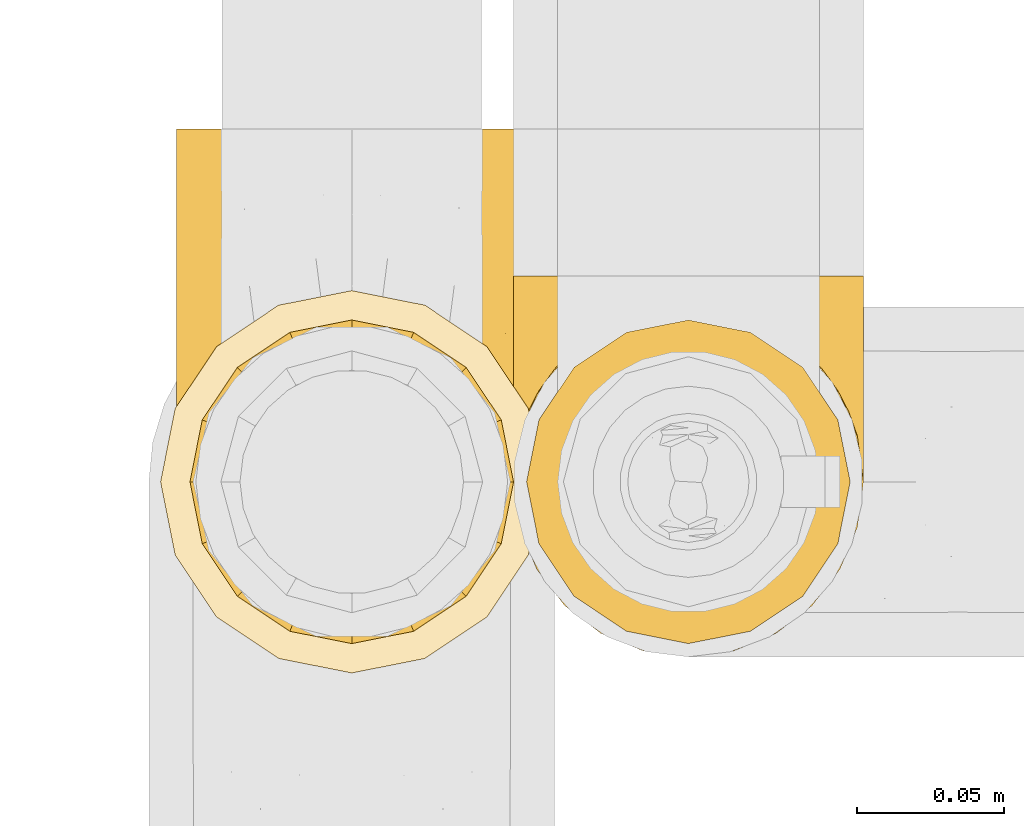
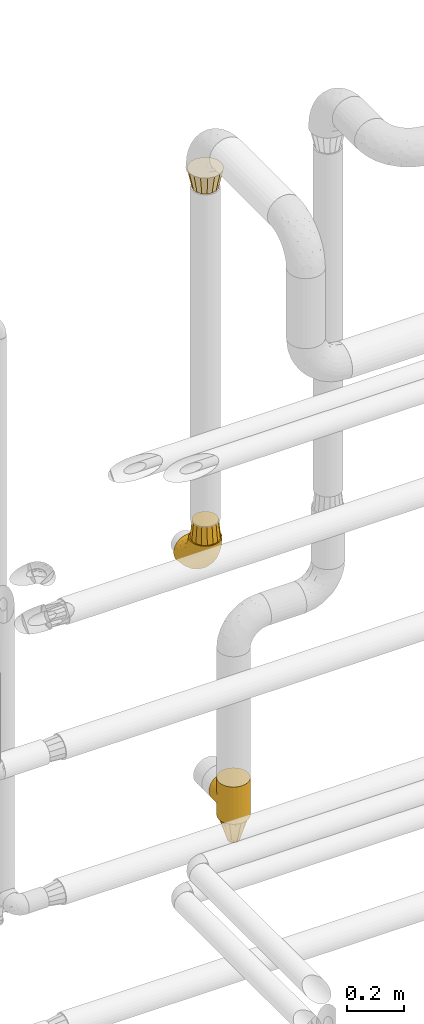
# One storey, part 483 of 827: 5 coverings.
"""IFC2X3 building model written with IfcOpenShell, lengths in millimetres."""

from ifc_helpers import new_model, entity, si_unit, converted_unit, derived_unit, direction, frame, origin, place, context, subcontext, project, spatial, faceted_brep, element, save


model = new_model("IFC2X3")

# Units and contexts
model_context = context("Model", 3, precision=0.01, world=origin(), true_north=direction((6.12303176911189e-17, 1.0)))
body_context = subcontext(model_context, "Body", "Model", "MODEL_VIEW")
ifc_project = project(units=[si_unit("LENGTHUNIT", "METRE", prefix="MILLI"), si_unit("AREAUNIT", "SQUARE_METRE"), si_unit("VOLUMEUNIT", "CUBIC_METRE"), converted_unit("PLANEANGLEUNIT", "DEGREE", entity("IfcRatioMeasure", 0.0174532925199433), si_unit("PLANEANGLEUNIT", "RADIAN"), dimensions=[0, 0, 0, 0, 0, 0, 0]), si_unit("MASSUNIT", "GRAM", prefix="KILO"), derived_unit("MASSDENSITYUNIT", [(si_unit("MASSUNIT", "GRAM", prefix="KILO"), 1), (si_unit("LENGTHUNIT", "METRE"), -3)]), derived_unit("MOMENTOFINERTIAUNIT", [(si_unit("LENGTHUNIT", "METRE"), 4)]), si_unit("TIMEUNIT", "SECOND"), si_unit("FREQUENCYUNIT", "HERTZ"), si_unit("THERMODYNAMICTEMPERATUREUNIT", "DEGREE_CELSIUS"), derived_unit("THERMALTRANSMITTANCEUNIT", [(si_unit("MASSUNIT", "GRAM", prefix="KILO"), 1), (si_unit("THERMODYNAMICTEMPERATUREUNIT", "KELVIN"), -1), (si_unit("TIMEUNIT", "SECOND"), -3)]), derived_unit("VOLUMETRICFLOWRATEUNIT", [(si_unit("LENGTHUNIT", "METRE"), 3), (si_unit("TIMEUNIT", "SECOND"), -1)]), derived_unit("MASSFLOWRATEUNIT", [(si_unit("MASSUNIT", "GRAM", prefix="KILO"), 1), (si_unit("TIMEUNIT", "SECOND"), -1)]), derived_unit("ROTATIONALFREQUENCYUNIT", [(si_unit("TIMEUNIT", "SECOND"), -1)]), si_unit("ELECTRICCURRENTUNIT", "AMPERE"), si_unit("ELECTRICVOLTAGEUNIT", "VOLT"), si_unit("POWERUNIT", "WATT"), si_unit("FORCEUNIT", "NEWTON", prefix="KILO"), si_unit("ILLUMINANCEUNIT", "LUX"), si_unit("LUMINOUSFLUXUNIT", "LUMEN"), si_unit("LUMINOUSINTENSITYUNIT", "CANDELA"), derived_unit("USERDEFINED", [(si_unit("MASSUNIT", "GRAM", prefix="KILO"), -1), (si_unit("LENGTHUNIT", "METRE"), -2), (si_unit("TIMEUNIT", "SECOND"), 3), (si_unit("LUMINOUSFLUXUNIT", "LUMEN"), 1)]), derived_unit("LINEARVELOCITYUNIT", [(si_unit("LENGTHUNIT", "METRE"), 1), (si_unit("TIMEUNIT", "SECOND"), -1)]), si_unit("PRESSUREUNIT", "PASCAL"), derived_unit("USERDEFINED", [(si_unit("LENGTHUNIT", "METRE"), -2), (si_unit("MASSUNIT", "GRAM", prefix="KILO"), 1), (si_unit("TIMEUNIT", "SECOND"), -2)]), derived_unit("LINEARFORCEUNIT", [(si_unit("MASSUNIT", "GRAM", prefix="KILO"), 1), (si_unit("LENGTHUNIT", "METRE"), 1), (si_unit("TIMEUNIT", "SECOND"), -2), (si_unit("LENGTHUNIT", "METRE"), -1)]), derived_unit("PLANARFORCEUNIT", [(si_unit("MASSUNIT", "GRAM", prefix="KILO"), 1), (si_unit("LENGTHUNIT", "METRE"), 1), (si_unit("TIMEUNIT", "SECOND"), -2), (si_unit("LENGTHUNIT", "METRE"), -2)])], contexts=[model_context])

# Site, building, storey
site_placement = place(None, origin())
site = spatial("IfcSite", under=ifc_project, at=site_placement, CompositionType="ELEMENT")
building_placement = place(site_placement, origin())
building = spatial("IfcBuilding", under=site, at=building_placement, CompositionType="ELEMENT")
storey_placement = place(building_placement, frame((0.0, 0.0, 28200.0)))
storey = spatial("IfcBuildingStorey", under=building, at=storey_placement, Name="08", CompositionType="ELEMENT", Elevation=28200.0)

# Coverings
covering_1_placement = place(storey_placement, frame((55549.95, 18574.89, 1587.07)))
element("IfcCovering", 1, at=covering_1_placement, inside=storey, Name=":ADSK_", ObjectType=":ADSK_", PredefinedType="INSULATION", context=body_context, shape_type="Brep", body=[
    faceted_brep([(119.1, 181.1, 47.85), (114.7, 181.1, 35.28), (107.61, 181.1, 23.99), (98.19, 181.1, 14.57), (86.9, 181.1, 7.48), (74.32, 181.1, 3.08), (61.1, 181.1, 1.6), (47.85, 181.1, 3.09), (35.28, 181.1, 7.49), (23.99, 181.1, 14.58), (14.57, 181.1, 24.0), (7.48, 181.1, 35.29), (3.08, 181.1, 47.87), (1.6, 181.1, 61.1), (3.09, 181.1, 74.34), (7.49, 181.1, 86.92), (14.58, 181.1, 98.2), (24.0, 181.1, 107.62), (35.29, 181.1, 114.71), (47.87, 181.1, 119.11), (61.1, 181.1, 120.6), (74.34, 181.1, 119.1), (86.92, 181.1, 114.7), (98.2, 181.1, 107.61), (107.62, 181.1, 98.19), (114.71, 181.1, 86.9), (119.11, 181.1, 74.32), (120.6, 181.1, 61.1), (45.7, 118.57, 181.1), (31.35, 112.62, 181.1), (19.02, 103.17, 181.1), (9.57, 90.85, 181.1), (3.62, 76.5, 181.1), (1.6, 61.1, 181.1), (3.62, 45.7, 181.1), (9.57, 31.35, 181.1), (19.02, 19.02, 181.1), (31.35, 9.57, 181.1), (45.7, 3.62, 181.1), (61.1, 1.6, 181.1), (76.5, 3.62, 181.1), (90.85, 9.57, 181.1), (103.17, 19.02, 181.1), (112.62, 31.35, 181.1), (118.57, 45.7, 181.1), (120.6, 61.1, 181.1), (118.57, 76.5, 181.1), (112.62, 90.85, 181.1), (103.17, 103.17, 181.1), (90.85, 112.62, 181.1), (76.5, 118.57, 181.1), (61.1, 120.6, 181.1), (95.88, 15.84, 149.36), (82.3, 10.89, 137.95), (94.1, 25.99, 112.73), (71.89, 6.8, 142.53), (61.1, 7.71, 134.64), (110.03, 148.3, 30.78), (80.11, 40.83, 74.16), (61.1, 25.64, 91.35), (61.1, 54.17, 54.17), (115.76, 56.92, 109.16), (113.03, 40.2, 132.51), (106.83, 45.07, 100.6), (118.0, 48.97, 143.49), (119.56, 66.12, 118.25), (91.22, 66.35, 53.89), (97.67, 45.15, 84.22), (83.16, 22.59, 106.32), (71.84, 15.89, 113.45), (106.27, 28.43, 137.68), (61.1, 134.64, 7.71), (79.29, 137.7, 9.86), (89.43, 106.92, 25.56), (76.37, 73.35, 40.03), (73.84, 104.34, 20.36), (118.7, 85.71, 85.71), (113.14, 75.83, 75.88), (114.84, 115.33, 51.26), (119.09, 132.84, 56.83), (120.6, 110.56, 84.01), (120.6, 84.01, 110.56), (120.6, 75.49, 127.29), (120.6, 66.97, 144.01), (61.1, 91.35, 25.64), (101.09, 137.45, 22.95), (106.71, 109.24, 40.15), (91.36, 148.74, 12.95), (116.15, 149.72, 42.03), (120.6, 166.46, 63.41), (120.6, 144.01, 66.97), (98.77, 108.21, 31.89), (120.6, 97.29, 97.29), (104.27, 67.3, 67.3), (120.6, 127.29, 75.49), (120.6, 63.41, 166.46), (114.26, 96.71, 141.36), (113.3, 111.53, 121.72), (106.08, 112.34, 138.16), (118.29, 79.69, 159.88), (119.17, 88.09, 128.08), (102.39, 126.83, 126.23), (119.07, 100.88, 110.87), (74.66, 121.74, 162.96), (72.06, 130.15, 146.61), (61.1, 125.2, 157.94), (107.18, 157.86, 102.08), (103.18, 144.96, 112.03), (111.64, 131.95, 107.36), (111.23, 95.04, 162.91), (101.44, 108.45, 157.88), (82.78, 166.95, 118.07), (95.99, 162.57, 111.72), (88.46, 120.76, 151.58), (85.34, 116.83, 167.61), (75.22, 141.74, 132.93), (61.1, 138.32, 138.32), (116.35, 144.64, 90.2), (119.46, 127.06, 87.09), (116.78, 126.54, 98.46), (85.13, 150.94, 122.87), (89.52, 133.58, 132.83), (119.0, 161.98, 76.52), (94.63, 149.89, 117.49), (113.92, 164.37, 90.0), (73.67, 158.61, 123.48), (61.1, 157.94, 125.2), (119.4, 112.57, 97.44), (97.35, 121.02, 139.94), (119.56, 141.14, 79.72), (117.72, 85.77, 145.56), (108.82, 101.62, 152.47), (16.12, 112.36, 138.17), (19.81, 126.84, 126.24), (8.9, 111.54, 121.74), (26.21, 162.57, 111.73), (15.02, 157.85, 102.09), (24.86, 121.04, 139.94), (5.84, 144.61, 90.22), (2.63, 141.17, 79.72), (2.73, 127.06, 87.08), (46.99, 141.76, 132.91), (47.54, 121.74, 162.97), (36.85, 116.83, 167.61), (10.96, 95.04, 162.91), (13.37, 101.62, 152.47), (7.93, 96.71, 141.36), (3.02, 88.09, 128.08), (2.89, 98.49, 112.07), (1.6, 84.01, 110.56), (3.9, 79.69, 159.88), (1.6, 63.41, 166.46), (26.96, 141.74, 121.68), (37.08, 150.97, 122.86), (20.75, 108.45, 157.88), (10.56, 131.95, 107.38), (50.11, 130.15, 146.61), (19.02, 144.96, 112.05), (48.54, 158.63, 123.48), (3.81, 114.02, 101.72), (8.27, 164.36, 90.01), (4.47, 85.77, 145.56), (39.43, 166.97, 118.07), (3.19, 161.97, 76.53), (32.68, 133.61, 132.81), (1.6, 144.01, 66.97), (1.6, 166.46, 63.41), (1.6, 127.29, 75.49), (5.87, 130.93, 97.07), (1.6, 97.29, 97.29), (1.6, 66.97, 144.01), (1.6, 75.49, 127.29), (1.6, 110.56, 84.01), (33.73, 120.76, 151.59), (28.09, 25.99, 112.73), (26.31, 15.84, 149.36), (15.92, 28.43, 137.68), (9.16, 40.2, 132.51), (50.3, 6.8, 142.53), (39.89, 10.89, 137.95), (50.35, 15.89, 113.45), (2.63, 66.12, 118.25), (15.36, 45.07, 100.6), (45.82, 73.35, 40.03), (30.97, 66.35, 53.89), (32.75, 106.93, 25.56), (3.49, 85.71, 85.71), (4.19, 48.97, 143.49), (39.03, 22.59, 106.32), (44.85, 103.99, 21.51), (42.89, 137.71, 9.86), (42.08, 40.83, 74.16), (6.03, 149.72, 42.04), (3.1, 132.83, 56.84), (6.43, 56.92, 109.16), (9.05, 75.83, 75.88), (12.15, 148.31, 30.8), (21.09, 137.46, 22.96), (24.52, 45.15, 84.22), (30.82, 148.74, 12.96), (7.35, 115.32, 51.28), (15.47, 109.25, 40.16), (17.92, 67.3, 67.3), (23.41, 108.22, 31.9)], [[[0, 1, 2, 3, 4, 5, 6, 7, 8, 9, 10, 11, 12, 13, 14, 15, 16, 17, 18, 19, 20, 21, 22, 23, 24, 25, 26, 27]], [[28, 29, 30, 31, 32, 33, 34, 35, 36, 37, 38, 39, 40, 41, 42, 43, 44, 45, 46, 47, 48, 49, 50, 51]], [[52, 53, 54]], [[55, 39, 56]], [[57, 2, 1]], [[58, 59, 60]], [[61, 62, 63]], [[64, 61, 65]], [[58, 66, 67]], [[53, 68, 54]], [[41, 40, 53]], [[53, 69, 68]], [[70, 42, 52]], [[42, 41, 52]], [[71, 5, 72]], [[73, 74, 75]], [[43, 70, 62]], [[45, 44, 64]], [[76, 77, 78]], [[79, 80, 76]], [[65, 81, 82, 83]], [[74, 60, 84]], [[85, 2, 57]], [[85, 57, 86]], [[2, 85, 3]], [[42, 70, 43]], [[5, 4, 72]], [[72, 87, 73]], [[4, 3, 87]], [[5, 71, 6]], [[75, 74, 84]], [[64, 62, 61]], [[79, 78, 88]], [[54, 67, 63]], [[74, 58, 60]], [[65, 76, 81]], [[79, 27, 89, 90]], [[75, 71, 72]], [[85, 86, 91]], [[78, 57, 88]], [[56, 69, 55]], [[76, 78, 79]], [[76, 80, 92, 81]], [[77, 76, 61]], [[69, 56, 59]], [[4, 87, 72]], [[91, 66, 73]], [[58, 74, 66]], [[3, 85, 87]], [[73, 87, 85]], [[88, 57, 1]], [[86, 57, 78]], [[77, 86, 78]], [[93, 66, 91]], [[73, 66, 74]], [[67, 93, 63]], [[1, 0, 88]], [[0, 27, 79]], [[0, 79, 88]], [[79, 90, 94, 80]], [[64, 83, 95, 45]], [[76, 65, 61]], [[83, 64, 65]], [[62, 44, 43]], [[62, 64, 44]], [[63, 62, 70]], [[54, 63, 70]], [[63, 93, 77]], [[63, 77, 61]], [[77, 93, 86]], [[67, 54, 68]], [[66, 93, 67]], [[53, 52, 41]], [[70, 52, 54]], [[58, 69, 59]], [[55, 69, 53]], [[69, 58, 68]], [[67, 68, 58]], [[53, 40, 55]], [[39, 55, 40]], [[71, 75, 84]], [[73, 75, 72]], [[91, 86, 93]], [[73, 85, 91]], [[96, 97, 98]], [[83, 99, 95]], [[82, 81, 100]], [[95, 99, 46]], [[101, 98, 97]], [[47, 46, 99]], [[97, 100, 102]], [[103, 104, 105]], [[106, 107, 108]], [[109, 48, 47]], [[48, 110, 49]], [[108, 101, 97]], [[111, 112, 22]], [[51, 50, 103]], [[113, 103, 114]], [[23, 22, 112]], [[115, 116, 104]], [[108, 117, 106]], [[112, 106, 23]], [[94, 118, 80]], [[108, 119, 117]], [[120, 115, 121]], [[112, 107, 106]], [[25, 122, 26]], [[122, 89, 26]], [[101, 123, 121]], [[109, 110, 48]], [[124, 25, 24]], [[125, 20, 126]], [[120, 111, 125]], [[110, 113, 114]], [[127, 97, 102]], [[106, 24, 23]], [[125, 115, 120]], [[111, 22, 21]], [[126, 115, 125]], [[117, 124, 106]], [[110, 98, 128]], [[117, 129, 124]], [[117, 118, 129]], [[100, 97, 96]], [[124, 122, 25]], [[83, 82, 130]], [[99, 130, 109]], [[100, 81, 102]], [[100, 130, 82]], [[130, 100, 96]], [[81, 92, 102]], [[127, 80, 118]], [[21, 20, 125]], [[111, 120, 123]], [[21, 125, 111]], [[115, 126, 116]], [[104, 116, 105]], [[101, 107, 123]], [[104, 121, 115]], [[128, 121, 113]], [[105, 51, 103]], [[121, 104, 113]], [[114, 103, 50]], [[113, 104, 103]], [[106, 124, 24]], [[94, 129, 118]], [[123, 107, 112]], [[101, 108, 107]], [[99, 109, 47]], [[131, 109, 96]], [[89, 122, 90]], [[89, 27, 26]], [[122, 129, 90]], [[97, 127, 119]], [[119, 127, 118]], [[102, 92, 127]], [[90, 129, 94]], [[80, 127, 92]], [[124, 129, 122]], [[117, 119, 118]], [[97, 119, 108]], [[50, 49, 114]], [[110, 114, 49]], [[109, 130, 96]], [[130, 99, 83]], [[128, 98, 101]], [[98, 110, 131]], [[121, 128, 101]], [[110, 128, 113]], [[46, 45, 95]], [[111, 123, 112]], [[121, 123, 120]], [[98, 131, 96]], [[110, 109, 131]], [[132, 133, 134]], [[135, 17, 136]], [[132, 137, 133]], [[138, 139, 140]], [[126, 141, 116]], [[105, 142, 51]], [[16, 136, 17]], [[142, 143, 28]], [[144, 145, 146]], [[147, 148, 149]], [[31, 150, 32]], [[150, 151, 32]], [[135, 152, 153]], [[30, 29, 154]], [[155, 136, 138]], [[31, 30, 144]], [[156, 116, 141]], [[136, 155, 157]], [[126, 158, 141]], [[159, 148, 134]], [[20, 19, 158]], [[156, 142, 105]], [[160, 136, 16]], [[147, 161, 146]], [[135, 18, 17]], [[18, 162, 19]], [[136, 157, 135]], [[146, 145, 132]], [[160, 163, 139]], [[16, 15, 160]], [[15, 14, 163]], [[164, 141, 153]], [[133, 155, 134]], [[152, 135, 157]], [[165, 163, 166]], [[163, 14, 166]], [[162, 135, 153]], [[29, 143, 154]], [[165, 167, 139]], [[162, 158, 19]], [[159, 134, 155]], [[167, 140, 139]], [[140, 168, 138]], [[159, 169, 148]], [[144, 150, 31]], [[161, 170, 150]], [[171, 170, 161]], [[149, 171, 147]], [[134, 147, 146]], [[134, 148, 147]], [[135, 162, 18]], [[169, 159, 172]], [[169, 149, 148]], [[158, 162, 153]], [[158, 153, 141]], [[158, 126, 20]], [[153, 152, 164]], [[116, 156, 105]], [[137, 164, 133]], [[156, 164, 173]], [[164, 156, 141]], [[142, 28, 51]], [[156, 173, 142]], [[143, 142, 173]], [[163, 160, 15]], [[136, 160, 138]], [[155, 133, 157]], [[133, 164, 152]], [[154, 144, 30]], [[144, 146, 161]], [[14, 13, 166]], [[172, 159, 140]], [[140, 167, 172]], [[168, 159, 155]], [[160, 139, 138]], [[165, 139, 163]], [[154, 143, 173]], [[29, 28, 143]], [[171, 161, 147]], [[144, 161, 150]], [[159, 168, 140]], [[155, 138, 168]], [[146, 132, 134]], [[137, 154, 173]], [[154, 137, 132]], [[164, 137, 173]], [[151, 150, 170]], [[151, 33, 32]], [[133, 152, 157]], [[144, 154, 145]], [[132, 145, 154]], [[174, 175, 176]], [[35, 34, 177]], [[178, 179, 180]], [[181, 170, 171, 149]], [[176, 182, 174]], [[183, 184, 185]], [[186, 149, 169, 172]], [[187, 33, 151, 170]], [[179, 188, 180]], [[34, 187, 177]], [[39, 38, 178]], [[189, 185, 190]], [[184, 183, 191]], [[175, 179, 37]], [[38, 37, 179]], [[35, 176, 36]], [[180, 59, 56]], [[192, 193, 12]], [[37, 36, 175]], [[181, 187, 170]], [[181, 186, 194]], [[176, 177, 182]], [[8, 7, 190]], [[194, 186, 195]], [[13, 12, 193]], [[196, 192, 11]], [[10, 9, 197]], [[60, 183, 84]], [[174, 182, 198]], [[197, 196, 10]], [[193, 172, 167, 165]], [[8, 199, 9]], [[189, 183, 185]], [[60, 59, 191]], [[200, 196, 201]], [[190, 199, 8]], [[7, 6, 71]], [[10, 196, 11]], [[202, 203, 184]], [[199, 185, 197]], [[7, 71, 190]], [[183, 60, 191]], [[189, 71, 84]], [[193, 186, 172]], [[200, 201, 195]], [[180, 191, 59]], [[185, 199, 190]], [[197, 9, 199]], [[201, 196, 197]], [[192, 196, 200]], [[203, 201, 197]], [[195, 201, 202]], [[191, 188, 198]], [[202, 201, 203]], [[193, 192, 200]], [[12, 11, 192]], [[186, 193, 200]], [[193, 165, 166, 13]], [[186, 181, 149]], [[187, 181, 194]], [[187, 194, 177]], [[187, 34, 33]], [[194, 195, 182]], [[35, 177, 176]], [[194, 182, 177]], [[182, 202, 198]], [[200, 195, 186]], [[182, 195, 202]], [[202, 184, 198]], [[191, 198, 184]], [[176, 175, 36]], [[179, 175, 174]], [[178, 180, 56]], [[179, 174, 188]], [[198, 188, 174]], [[191, 180, 188]], [[39, 178, 56]], [[38, 179, 178]], [[71, 189, 190]], [[84, 183, 189]], [[197, 185, 203]], [[184, 203, 185]]]),
])
covering_2_placement = place(storey_placement, frame((55664.4, 18574.89, 535.5)))
element("IfcCovering", 2, at=covering_2_placement, inside=storey, Name=":ADSK_", ObjectType=":ADSK_", PredefinedType="INSULATION", context=body_context, shape_type="Brep", body=[
    faceted_brep([(120.05, 69.11, 71.99), (120.6, 61.1, 0.0), (118.57, 76.5, 0.0), (112.62, 90.85, 0.0), (115.66, 84.83, 56.27), (106.54, 99.5, 41.59), (103.17, 103.17, 0.0), (111.72, 92.36, 48.74), (120.6, 61.1, 80.0), (120.05, 69.11, 88.01), (120.6, 61.1, 160.0), (118.42, 77.05, 64.05), (100.03, 106.08, 35.01), (90.85, 112.62, 0.0), (82.85, 116.47, 24.62), (83.67, 115.6, 0.0), (76.5, 118.57, 0.0), (68.8, 119.58, 0.0), (61.1, 120.6, 0.0), (61.1, 120.6, 20.5), (68.8, 119.58, 160.0), (61.1, 120.6, 139.5), (61.1, 120.6, 160.0), (92.14, 111.85, 29.24), (72.35, 119.52, 21.57), (77.6, 118.0, 23.1), (66.72, 120.06, 21.04), (49.85, 119.52, 21.57), (53.4, 119.58, 0.0), (45.7, 118.57, 0.0), (39.34, 116.48, 24.62), (38.52, 115.6, 0.0), (31.35, 112.62, 0.0), (22.16, 106.09, 35.01), (19.02, 103.17, 0.0), (55.47, 120.06, 21.04), (53.4, 119.58, 160.0), (30.06, 111.86, 29.24), (44.6, 118.0, 23.1), (15.66, 99.51, 41.59), (10.47, 92.37, 48.73), (9.57, 90.85, 0.0), (6.54, 84.83, 56.26), (3.62, 76.5, 0.0), (2.14, 69.11, 71.99), (1.6, 61.1, 0.0), (3.77, 77.05, 64.05), (1.6, 61.1, 80.0), (2.14, 69.11, 88.01), (1.6, 61.1, 160.0), (31.35, 9.57, 160.0), (45.7, 3.62, 160.0), (61.1, 1.6, 160.0), (76.5, 3.62, 160.0), (90.85, 9.57, 160.0), (103.17, 19.02, 160.0), (112.62, 31.35, 160.0), (118.57, 45.7, 160.0), (118.57, 76.5, 160.0), (112.62, 90.85, 160.0), (103.17, 103.17, 160.0), (90.85, 112.62, 160.0), (83.67, 115.6, 160.0), (76.5, 118.57, 160.0), (45.7, 118.57, 160.0), (38.52, 115.6, 160.0), (31.35, 112.62, 160.0), (19.02, 103.17, 160.0), (9.57, 90.85, 160.0), (3.62, 76.5, 160.0), (3.62, 45.7, 160.0), (9.57, 31.35, 160.0), (19.02, 19.02, 160.0), (118.57, 45.7, 0.0), (112.62, 31.35, 0.0), (103.17, 19.02, 0.0), (90.85, 9.57, 0.0), (76.5, 3.62, 0.0), (61.1, 1.6, 0.0), (45.7, 3.62, 0.0), (31.35, 9.57, 0.0), (19.02, 19.02, 0.0), (9.57, 31.35, 0.0), (3.62, 45.7, 0.0), (118.42, 77.05, 95.95), (115.66, 84.83, 103.73), (111.72, 92.36, 111.26), (106.54, 99.5, 118.41), (100.03, 106.08, 124.99), (92.14, 111.85, 130.76), (82.85, 116.47, 135.38), (77.6, 118.0, 136.9), (72.35, 119.52, 138.43), (66.72, 120.06, 138.96), (49.85, 119.52, 138.43), (44.6, 118.0, 136.9), (39.34, 116.48, 135.38), (30.06, 111.86, 130.76), (22.16, 106.09, 124.99), (55.47, 120.06, 138.96), (15.66, 99.51, 118.41), (6.54, 84.83, 103.74), (3.77, 77.05, 95.95), (10.47, 92.37, 111.27), (118.57, 131.1, 64.6), (112.62, 131.1, 50.25), (103.17, 131.1, 37.93), (90.85, 131.1, 28.47), (83.67, 131.1, 25.5), (76.5, 131.1, 22.53), (72.65, 131.1, 22.02), (68.8, 131.1, 21.51), (64.95, 131.1, 21.01), (61.1, 131.1, 20.5), (57.25, 131.1, 21.01), (53.4, 131.1, 21.51), (49.55, 131.1, 22.02), (45.7, 131.1, 22.53), (38.52, 131.1, 25.5), (31.35, 131.1, 28.47), (19.02, 131.1, 37.93), (9.57, 131.1, 50.25), (3.62, 131.1, 64.6), (1.6, 131.1, 80.0), (3.62, 131.1, 95.4), (9.57, 131.1, 109.75), (19.02, 131.1, 122.07), (31.35, 131.1, 131.53), (38.52, 131.1, 134.5), (45.7, 131.1, 137.47), (49.55, 131.1, 137.98), (53.4, 131.1, 138.49), (57.25, 131.1, 138.99), (61.1, 131.1, 139.5), (64.95, 131.1, 138.99), (68.8, 131.1, 138.49), (72.65, 131.1, 137.98), (76.5, 131.1, 137.47), (83.67, 131.1, 134.5), (90.85, 131.1, 131.53), (103.17, 131.1, 122.07), (112.62, 131.1, 109.75), (118.57, 131.1, 95.4), (120.6, 131.1, 80.0)], [[[0, 1, 2]], [[2, 3, 4]], [[5, 3, 6]], [[5, 7, 3]], [[0, 8, 1]], [[8, 9, 10]], [[4, 11, 2]], [[7, 4, 3]], [[0, 2, 11]], [[12, 6, 13]], [[14, 13, 15, 16]], [[17, 18, 19]], [[20, 21, 22]], [[23, 12, 13]], [[16, 24, 25, 14]], [[17, 19, 26, 24]], [[24, 16, 17]], [[23, 13, 14]], [[6, 12, 5]], [[27, 28, 29]], [[30, 29, 31, 32]], [[33, 32, 34]], [[28, 27, 35, 19]], [[19, 18, 28]], [[22, 21, 36]], [[37, 30, 32]], [[33, 37, 32]], [[29, 30, 38, 27]], [[34, 39, 33]], [[40, 39, 41]], [[41, 39, 34]], [[42, 41, 43]], [[44, 43, 45]], [[42, 40, 41]], [[44, 46, 43]], [[47, 44, 45]], [[48, 47, 49]], [[42, 43, 46]], [[50, 51, 52, 53, 54, 55, 56, 57, 10, 58, 59, 60, 61, 62, 63, 20, 22, 36, 64, 65, 66, 67, 68, 69, 49, 70, 71, 72]], [[73, 74, 75, 76, 77, 78, 79, 80, 81, 82, 83, 45, 43, 41, 34, 32, 31, 29, 28, 18, 17, 16, 15, 13, 6, 3, 2, 1]], [[76, 75, 55, 54]], [[52, 78, 77, 53]], [[53, 77, 76, 54]], [[56, 74, 73, 57]], [[1, 8, 10, 57, 73]], [[55, 75, 74, 56]], [[84, 85, 58]], [[9, 84, 58]], [[10, 9, 58]], [[59, 86, 87]], [[59, 58, 85]], [[59, 87, 60]], [[86, 59, 85]], [[88, 89, 61]], [[90, 63, 62, 61]], [[63, 90, 91, 92]], [[20, 92, 93, 21]], [[89, 90, 61]], [[60, 88, 61]], [[92, 20, 63]], [[88, 60, 87]], [[64, 94, 95, 96]], [[94, 64, 36]], [[97, 98, 66]], [[96, 66, 65, 64]], [[96, 97, 66]], [[36, 21, 99, 94]], [[98, 67, 66]], [[98, 100, 67]], [[101, 102, 69]], [[102, 48, 69]], [[100, 103, 68]], [[101, 68, 103]], [[101, 69, 68]], [[48, 49, 69]], [[100, 68, 67]], [[47, 45, 83, 70, 49]], [[70, 83, 82, 71]], [[82, 81, 72, 71]], [[72, 81, 80, 50]], [[50, 80, 79, 51]], [[51, 79, 78, 52]], [[104, 105, 106, 107, 108, 109, 110, 111, 112, 113, 114, 115, 116, 117, 118, 119, 120, 121, 122, 123, 124, 125, 126, 127, 128, 129, 130, 131, 132, 133, 134, 135, 136, 137, 138, 139, 140, 141, 142, 143]], [[24, 111, 110, 109]], [[107, 106, 12]], [[19, 112, 26]], [[14, 108, 107]], [[112, 19, 113]], [[112, 111, 26]], [[108, 25, 109]], [[23, 14, 107]], [[12, 23, 107]], [[25, 108, 14]], [[24, 109, 25]], [[106, 5, 12]], [[7, 5, 105]], [[105, 5, 106]], [[4, 105, 104]], [[0, 104, 143]], [[4, 7, 105]], [[0, 11, 104]], [[8, 0, 143]], [[4, 104, 11]], [[111, 24, 26]], [[9, 143, 142]], [[142, 141, 85]], [[87, 141, 140]], [[87, 86, 141]], [[9, 8, 143]], [[93, 135, 134]], [[85, 84, 142]], [[86, 85, 141]], [[9, 142, 84]], [[21, 134, 133]], [[88, 140, 139]], [[138, 137, 91]], [[21, 93, 134]], [[137, 92, 91]], [[89, 88, 139]], [[90, 139, 138]], [[90, 138, 91]], [[92, 135, 93]], [[92, 137, 136, 135]], [[89, 139, 90]], [[140, 88, 87]], [[94, 131, 130, 129]], [[96, 128, 127]], [[98, 127, 126]], [[132, 21, 133]], [[132, 131, 99]], [[128, 95, 129]], [[97, 96, 127]], [[98, 97, 127]], [[95, 128, 96]], [[94, 129, 95]], [[126, 100, 98]], [[103, 100, 125]], [[125, 100, 126]], [[101, 125, 124]], [[48, 124, 123]], [[101, 103, 125]], [[48, 102, 124]], [[47, 48, 123]], [[101, 124, 102]], [[21, 132, 99]], [[131, 94, 99]], [[44, 123, 122]], [[122, 121, 42]], [[39, 121, 120]], [[39, 40, 121]], [[44, 47, 123]], [[35, 115, 114]], [[42, 46, 122]], [[40, 42, 121]], [[44, 122, 46]], [[19, 114, 113]], [[33, 120, 119]], [[118, 117, 38]], [[19, 35, 114]], [[117, 27, 38]], [[37, 33, 119]], [[30, 119, 118]], [[30, 118, 38]], [[27, 115, 35]], [[27, 117, 116, 115]], [[37, 119, 30]], [[120, 33, 39]]]),
])
covering_3_placement = place(storey_placement, frame((55668.9, 18579.39, 430.5)))
element("IfcCovering", 3, at=covering_3_placement, inside=storey, Name=":ADSK_", ObjectType=":ADSK_", PredefinedType="INSULATION", context=body_context, shape_type="Brep", body=[
    faceted_brep([(101.45, 86.56, 105.0), (95.49, 95.49, 105.0), (86.56, 101.45, 105.0), (77.64, 107.41, 105.0), (67.12, 109.5, 105.0), (56.6, 111.6, 105.0), (46.07, 109.5, 105.0), (35.55, 107.41, 105.0), (26.63, 101.45, 105.0), (17.7, 95.49, 105.0), (11.74, 86.56, 105.0), (5.78, 77.64, 105.0), (3.69, 67.12, 105.0), (1.6, 56.6, 105.0), (3.69, 46.07, 105.0), (5.78, 35.55, 105.0), (11.74, 26.63, 105.0), (17.7, 17.7, 105.0), (26.63, 11.74, 105.0), (35.55, 5.78, 105.0), (46.07, 3.69, 105.0), (56.6, 1.6, 105.0), (67.12, 3.69, 105.0), (77.64, 5.78, 105.0), (86.56, 11.74, 105.0), (95.49, 17.7, 105.0), (101.45, 26.63, 105.0), (107.41, 35.55, 105.0), (109.5, 46.07, 105.0), (111.6, 56.6, 105.0), (109.5, 67.12, 105.0), (107.41, 77.64, 105.0), (76.08, 45.35, 0.0), (71.96, 41.23, 0.0), (67.85, 37.11, 0.0), (62.22, 35.6, 0.0), (56.6, 34.1, 0.0), (50.97, 35.6, 0.0), (45.35, 37.11, 0.0), (41.23, 41.23, 0.0), (37.11, 45.35, 0.0), (35.6, 50.97, 0.0), (34.1, 56.6, 0.0), (35.6, 62.22, 0.0), (37.11, 67.85, 0.0), (41.23, 71.96, 0.0), (45.35, 76.08, 0.0), (50.97, 77.59, 0.0), (56.6, 79.1, 0.0), (62.22, 77.59, 0.0), (67.85, 76.08, 0.0), (71.96, 71.96, 0.0), (76.08, 67.85, 0.0), (77.59, 62.22, 0.0), (79.1, 56.6, 0.0), (77.59, 50.97, 0.0)], [[[0, 1, 2, 3, 4, 5, 6, 7, 8, 9, 10, 11, 12, 13, 14, 15, 16, 17, 18, 19, 20, 21, 22, 23, 24, 25, 26, 27, 28, 29, 30, 31]], [[32, 33, 34, 35, 36, 37, 38, 39, 40, 41, 42, 43, 44, 45, 46, 47, 48, 49, 50, 51, 52, 53, 54, 55]], [[6, 5, 48]], [[44, 10, 45]], [[45, 8, 46]], [[48, 47, 6]], [[9, 45, 10]], [[8, 7, 46]], [[8, 45, 9]], [[42, 12, 43]], [[47, 7, 6]], [[47, 46, 7]], [[12, 42, 13]], [[11, 44, 43]], [[12, 11, 43]], [[44, 11, 10]], [[14, 13, 42]], [[38, 18, 39]], [[39, 16, 40]], [[42, 41, 14]], [[17, 39, 18]], [[16, 15, 40]], [[16, 39, 17]], [[36, 20, 37]], [[41, 15, 14]], [[41, 40, 15]], [[20, 36, 21]], [[19, 38, 37]], [[20, 19, 37]], [[38, 19, 18]], [[22, 21, 36]], [[32, 26, 33]], [[33, 24, 34]], [[36, 35, 22]], [[25, 33, 26]], [[24, 23, 34]], [[24, 33, 25]], [[54, 28, 55]], [[35, 23, 22]], [[35, 34, 23]], [[28, 54, 29]], [[27, 32, 55]], [[28, 27, 55]], [[32, 27, 26]], [[30, 29, 54]], [[50, 2, 51]], [[51, 0, 52]], [[54, 53, 30]], [[1, 51, 2]], [[0, 31, 52]], [[0, 51, 1]], [[48, 4, 49]], [[53, 31, 30]], [[53, 52, 31]], [[4, 48, 5]], [[3, 50, 49]], [[4, 3, 49]], [[50, 3, 2]]]),
])
covering_4_placement = place(storey_placement, frame((55544.45, 18569.39, 3269.74)))
element("IfcCovering", 4, at=covering_4_placement, inside=storey, Name=":ADSK_", ObjectType=":ADSK_", PredefinedType="INSULATION", context=body_context, shape_type="Brep", body=[
    faceted_brep([(57.51, 20.9, 0.0), (48.42, 22.71, 0.0), (40.71, 27.86, 0.0), (33.01, 33.01, 0.0), (27.86, 40.71, 0.0), (22.71, 48.42, 0.0), (20.9, 57.51, 0.0), (19.1, 66.6, 0.0), (20.9, 75.68, 0.0), (22.71, 84.77, 0.0), (27.86, 92.48, 0.0), (33.01, 100.18, 0.0), (40.71, 105.33, 0.0), (48.42, 110.48, 0.0), (57.51, 112.29, 0.0), (66.6, 114.1, 0.0), (75.68, 112.29, 0.0), (84.77, 110.48, 0.0), (92.48, 105.33, 0.0), (100.18, 100.18, 0.0), (105.33, 92.48, 0.0), (110.48, 84.77, 0.0), (112.29, 75.68, 0.0), (114.1, 66.6, 0.0), (112.29, 57.51, 0.0), (110.48, 48.42, 0.0), (105.33, 40.71, 0.0), (100.18, 33.01, 0.0), (92.48, 27.86, 0.0), (84.77, 22.71, 0.0), (75.68, 20.9, 0.0), (66.6, 19.1, 0.0), (131.6, 66.6, 80.0), (129.84, 75.43, 80.0), (126.65, 91.47, 80.0), (119.6, 102.01, 80.0), (112.56, 112.56, 80.0), (102.01, 119.6, 80.0), (91.47, 126.65, 80.0), (79.03, 129.12, 80.0), (66.6, 131.6, 80.0), (57.76, 129.84, 80.0), (41.72, 126.65, 80.0), (31.18, 119.6, 80.0), (20.63, 112.56, 80.0), (13.59, 102.01, 80.0), (6.54, 91.47, 80.0), (4.07, 79.03, 80.0), (1.6, 66.6, 80.0), (3.35, 57.76, 80.0), (6.54, 41.72, 80.0), (13.59, 31.18, 80.0), (20.63, 20.63, 80.0), (31.18, 13.59, 80.0), (41.72, 6.54, 80.0), (54.16, 4.07, 80.0), (66.6, 1.6, 80.0), (75.43, 3.35, 80.0), (91.47, 6.54, 80.0), (102.01, 13.59, 80.0), (112.56, 20.63, 80.0), (119.6, 31.18, 80.0), (126.65, 41.72, 80.0), (129.12, 54.16, 80.0)], [[[0, 1, 2, 3, 4, 5, 6, 7, 8, 9, 10, 11, 12, 13, 14, 15, 16, 17, 18, 19, 20, 21, 22, 23, 24, 25, 26, 27, 28, 29, 30, 31]], [[32, 33, 34, 35, 36, 37, 38, 39, 40, 41, 42, 43, 44, 45, 46, 47, 48, 49, 50, 51, 52, 53, 54, 55, 56, 57, 58, 59, 60, 61, 62, 63]], [[58, 57, 56, 31, 30, 29]], [[59, 58, 29, 28, 27, 60]], [[27, 26, 25, 62, 61, 60]], [[23, 32, 63, 62, 25, 24]], [[50, 49, 48, 7, 6, 5]], [[51, 50, 5, 4, 3, 52]], [[3, 2, 1, 54, 53, 52]], [[31, 56, 55, 54, 1, 0]], [[42, 41, 40, 15, 14, 13]], [[43, 42, 13, 12, 11, 44]], [[11, 10, 9, 46, 45, 44]], [[7, 48, 47, 46, 9, 8]], [[34, 33, 32, 23, 22, 21]], [[35, 34, 21, 20, 19, 36]], [[19, 18, 17, 38, 37, 36]], [[15, 40, 39, 38, 17, 16]]]),
])
covering_5_placement = place(storey_placement, frame((55554.45, 18579.39, 1768.17)))
element("IfcCovering", 5, at=covering_5_placement, inside=storey, Name=":ADSK_", ObjectType=":ADSK_", PredefinedType="INSULATION", context=body_context, shape_type="Brep", body=[
    faceted_brep([(74.77, 12.71, 75.0), (82.48, 17.86, 75.0), (90.18, 23.01, 75.0), (95.33, 30.71, 75.0), (100.48, 38.42, 75.0), (102.29, 47.51, 75.0), (104.1, 56.6, 75.0), (102.29, 65.68, 75.0), (100.48, 74.77, 75.0), (95.33, 82.48, 75.0), (90.18, 90.18, 75.0), (82.48, 95.33, 75.0), (74.77, 100.48, 75.0), (65.68, 102.29, 75.0), (56.6, 104.1, 75.0), (47.51, 102.29, 75.0), (38.42, 100.48, 75.0), (30.71, 95.33, 75.0), (23.01, 90.18, 75.0), (17.86, 82.48, 75.0), (12.71, 74.77, 75.0), (10.9, 65.68, 75.0), (9.1, 56.6, 75.0), (10.9, 47.51, 75.0), (12.71, 38.42, 75.0), (17.86, 30.71, 75.0), (23.01, 23.01, 75.0), (30.71, 17.86, 75.0), (38.42, 12.71, 75.0), (47.51, 10.9, 75.0), (56.6, 9.1, 75.0), (65.68, 10.9, 75.0), (1.6, 56.6, 0.0), (3.14, 64.35, 0.0), (5.78, 77.64, 0.0), (11.74, 86.56, 0.0), (17.7, 95.49, 0.0), (26.63, 101.45, 0.0), (35.55, 107.41, 0.0), (46.07, 109.5, 0.0), (56.6, 111.6, 0.0), (64.35, 110.05, 0.0), (77.64, 107.41, 0.0), (86.56, 101.45, 0.0), (95.49, 95.49, 0.0), (101.45, 86.56, 0.0), (107.41, 77.64, 0.0), (109.5, 67.12, 0.0), (111.6, 56.6, 0.0), (110.05, 48.84, 0.0), (107.41, 35.55, 0.0), (101.45, 26.63, 0.0), (95.49, 17.7, 0.0), (86.56, 11.74, 0.0), (77.64, 5.78, 0.0), (67.12, 3.69, 0.0), (56.6, 1.6, 0.0), (48.84, 3.14, 0.0), (35.55, 5.78, 0.0), (26.63, 11.74, 0.0), (17.7, 17.7, 0.0), (11.74, 26.63, 0.0), (5.78, 35.55, 0.0), (3.69, 46.07, 0.0)], [[[0, 1, 2, 3, 4, 5, 6, 7, 8, 9, 10, 11, 12, 13, 14, 15, 16, 17, 18, 19, 20, 21, 22, 23, 24, 25, 26, 27, 28, 29, 30, 31]], [[32, 33, 34, 35, 36, 37, 38, 39, 40, 41, 42, 43, 44, 45, 46, 47, 48, 49, 50, 51, 52, 53, 54, 55, 56, 57, 58, 59, 60, 61, 62, 63]], [[58, 57, 56, 30, 29, 28]], [[27, 26, 60, 59, 58, 28]], [[26, 25, 24, 62, 61, 60]], [[62, 24, 23, 22, 32, 63]], [[50, 49, 48, 6, 5, 4]], [[3, 2, 52, 51, 50, 4]], [[2, 1, 0, 54, 53, 52]], [[54, 0, 31, 30, 56, 55]], [[42, 41, 40, 14, 13, 12]], [[11, 10, 44, 43, 42, 12]], [[10, 9, 8, 46, 45, 44]], [[46, 8, 7, 6, 48, 47]], [[34, 33, 32, 22, 21, 20]], [[19, 18, 36, 35, 34, 20]], [[18, 17, 16, 38, 37, 36]], [[38, 16, 15, 14, 40, 39]]]),
])

save(model, "model.ifc")
